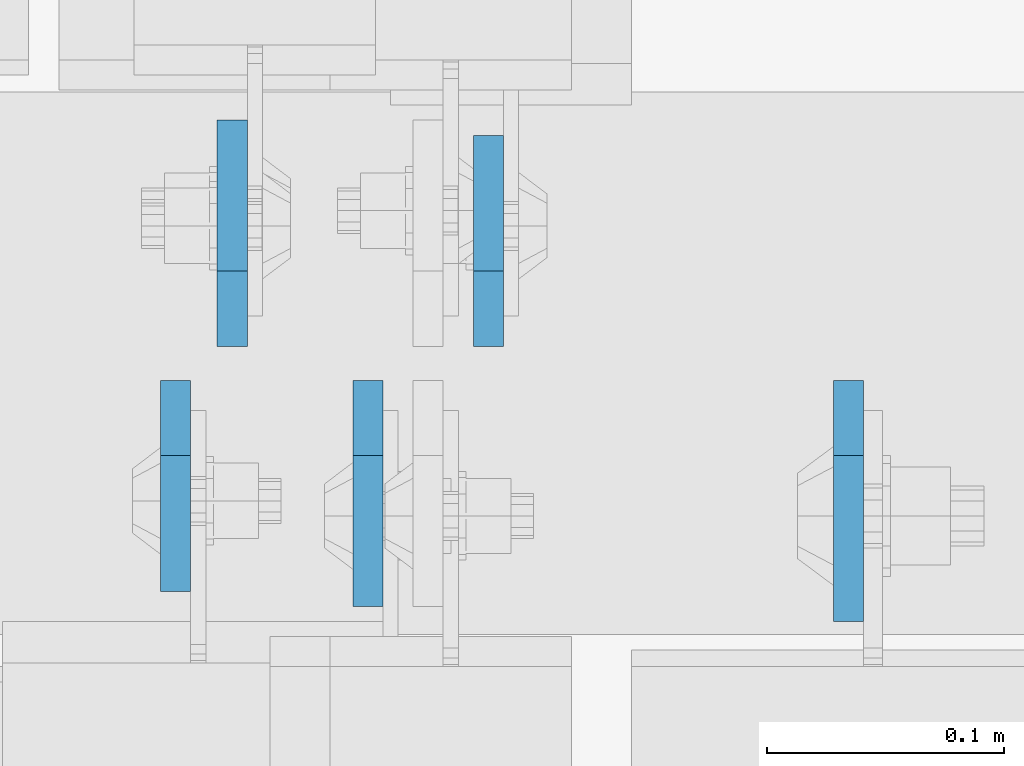
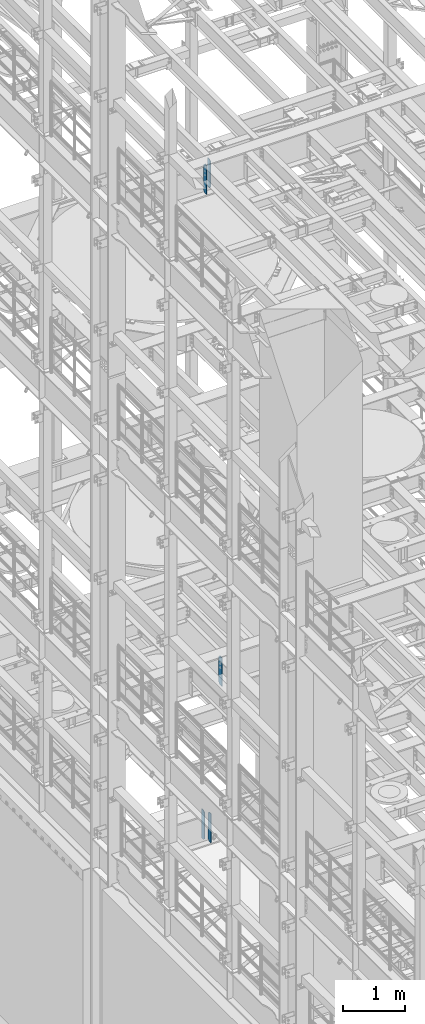
# One storey, part 1701 of 1876: 5 plates, 3 elements without a shape of their own.
"""IFC2X3 building model written with IfcOpenShell, lengths in millimetres."""

from ifc_helpers import new_model, si_unit, frame, origin_with_axes, place, context, subcontext, project, spatial, faceted_brep, material, type_object, element, aggregate, save


model = new_model("IFC2X3")

# Units and contexts
model_context = context("Model", 3, precision=1e-05, world=origin_with_axes())
body_context = subcontext(model_context, "Body", "Model", "MODEL_VIEW")
ifc_project = project(units=[si_unit("LENGTHUNIT", "METRE", prefix="MILLI"), si_unit("AREAUNIT", "SQUARE_METRE"), si_unit("VOLUMEUNIT", "CUBIC_METRE"), si_unit("MASSUNIT", "GRAM", prefix="KILO"), si_unit("TIMEUNIT", "SECOND"), si_unit("PLANEANGLEUNIT", "RADIAN"), si_unit("SOLIDANGLEUNIT", "STERADIAN"), si_unit("THERMODYNAMICTEMPERATUREUNIT", "DEGREE_CELSIUS"), si_unit("LUMINOUSINTENSITYUNIT", "LUMEN")], contexts=[model_context])

# Site, building, storey
site_placement = place(None, origin_with_axes())
site = spatial("IfcSite", under=ifc_project, at=site_placement, CompositionType="ELEMENT")
building_placement = place(site_placement, origin_with_axes())
building = spatial("IfcBuilding", under=site, at=building_placement, Name="Undefined", CompositionType="ELEMENT")
storey_placement = place(building_placement, origin_with_axes())
storey = spatial("IfcBuildingStorey", under=building, at=storey_placement, Name="Undefined", CompositionType="ELEMENT", Elevation=0.0)

# Assembly, plates
assembly_1_placement = place(storey_placement, origin_with_axes())
assembly_1 = element("IfcElementAssembly", 1, at=assembly_1_placement, inside=storey, Name="BEAM", AssemblyPlace="NOTDEFINED", PredefinedType="RIGID_FRAME")
ifc_material = material(Name="STEEL/A36")
plate_type_1 = type_object("IfcPlateType", PredefinedType="NOTDEFINED")
plate_1_placement = place(assembly_1_placement, frame((1789.11249990463, 7612.85625, 17386.3), z_axis=(0.0, 0.0, 1.0), x_axis=(0.0, -1.0, 0.0)))
plate_1 = element("IfcPlate", 2, at=plate_1_placement, type_object=plate_type_1, material=ifc_material, Name="PLATE", context=body_context, shape_type="Brep", body=[
    faceted_brep([(0.0, -6.34999999999991, 31.75), (0.0, -6.34999999999991, 539.75), (0.0, 6.34999999999991, 539.75), (0.0, 6.34999999999991, 31.75), (31.75, -6.34999999999991, 571.5), (31.75, 6.34999999999991, 571.5), (88.9000015258789, -6.34999999999991, 571.5), (88.9000015258789, 6.34999999999991, 571.5), (88.9000015258789, -6.34999999999991, 0.0), (88.9000015258789, 6.34999999999991, 0.0), (31.75, -6.34999999999991, 0.0), (31.75, 6.34999999999991, 0.0)], [[[0, 1, 2, 3]], [[1, 4, 5, 2]], [[4, 6, 7, 5]], [[6, 8, 9, 7]], [[8, 10, 11, 9]], [[10, 0, 3, 11]], [[5, 7, 9, 11, 3, 2]], [[10, 8, 6, 4, 1, 0]]]),
])
plate_2_placement = place(assembly_1_placement, frame((1920.87499990463, 7627.14375, 17386.3), z_axis=(0.0, 0.0, 1.0), x_axis=(0.0, 1.0, 0.0)))
plate_2 = element("IfcPlate", 3, at=plate_2_placement, type_object=plate_type_1, material=ifc_material, Name="PLATE", context=body_context, shape_type="Brep", body=[
    faceted_brep([(0.0, -6.34999999999991, 31.75), (0.0, -6.34999999999991, 539.75), (0.0, 6.34999999999991, 539.75), (0.0, 6.34999999999991, 31.75), (31.75, -6.34999999999991, 571.5), (31.75, 6.34999999999991, 571.5), (88.9000015258789, -6.34999999999991, 571.5), (88.9000015258789, 6.34999999999991, 571.5), (88.9000015258789, -6.34999999999991, 0.0), (88.9000015258789, 6.34999999999991, 0.0), (31.75, -6.34999999999991, 0.0), (31.75, 6.34999999999991, 0.0)], [[[0, 1, 2, 3]], [[1, 4, 5, 2]], [[4, 6, 7, 5]], [[6, 8, 9, 7]], [[8, 10, 11, 9]], [[10, 0, 3, 11]], [[5, 7, 9, 11, 3, 2]], [[10, 8, 6, 4, 1, 0]]]),
])
aggregate(assembly_1, [plate_1, plate_2])

assembly_2_placement = place(storey_placement, origin_with_axes())
assembly_2 = element("IfcElementAssembly", 4, at=assembly_2_placement, inside=storey, Name="BEAM", AssemblyPlace="NOTDEFINED", PredefinedType="RIGID_FRAME")
plate_type_2 = type_object("IfcPlateType", PredefinedType="NOTDEFINED")
plate_3_placement = place(assembly_2_placement, frame((1870.07499990463, 7612.85625, 4535.4875), z_axis=(0.0, 0.0, 1.0), x_axis=(0.0, -1.0, 0.0)))
plate_3 = element("IfcPlate", 5, at=plate_3_placement, type_object=plate_type_2, material=ifc_material, Name="PLATE", context=body_context, shape_type="Brep", body=[
    faceted_brep([(0.0, -6.34999999999991, 31.75), (0.0, -6.35000000000036, 538.162475585938), (0.0, 6.35000000000036, 538.162475585938), (0.0, 6.34999999999991, 31.75), (31.75, -6.35000000000036, 569.912475585938), (31.75, 6.35000000000036, 569.912475585938), (95.25, -6.35000000000036, 569.912475585938), (95.25, 6.35000000000036, 569.912475585938), (95.25, -6.35000000000036, 0.0), (95.25, 6.35000000000036, 0.0), (31.75, -6.34999999999991, 0.0), (31.75, 6.34999999999991, 0.0)], [[[0, 1, 2, 3]], [[1, 4, 5, 2]], [[4, 6, 7, 5]], [[6, 8, 9, 7]], [[8, 10, 11, 9]], [[10, 0, 3, 11]], [[5, 7, 9, 11, 3, 2]], [[10, 8, 6, 4, 1, 0]]]),
])
plate_4_placement = place(assembly_2_placement, frame((1812.92499990463, 7627.14375, 4535.4875), z_axis=(0.0, 0.0, 1.0), x_axis=(0.0, 1.0, 0.0)))
plate_4 = element("IfcPlate", 6, at=plate_4_placement, type_object=plate_type_2, material=ifc_material, Name="PLATE", context=body_context, shape_type="Brep", body=[
    faceted_brep([(0.0, -6.34999999999991, 31.75), (0.0, -6.35000000000036, 538.162475585938), (0.0, 6.35000000000036, 538.162475585938), (0.0, 6.34999999999991, 31.75), (31.75, -6.35000000000036, 569.912475585938), (31.75, 6.35000000000036, 569.912475585938), (95.25, -6.35000000000036, 569.912475585938), (95.25, 6.35000000000036, 569.912475585938), (95.25, -6.35000000000036, 0.0), (95.25, 6.35000000000036, 0.0), (31.75, -6.34999999999991, 0.0), (31.75, 6.34999999999991, 0.0)], [[[0, 1, 2, 3]], [[1, 4, 5, 2]], [[4, 6, 7, 5]], [[6, 8, 9, 7]], [[8, 10, 11, 9]], [[10, 0, 3, 11]], [[5, 7, 9, 11, 3, 2]], [[10, 8, 6, 4, 1, 0]]]),
])
aggregate(assembly_2, [plate_3, plate_4])

# Assembly, plate
assembly_3_placement = place(storey_placement, origin_with_axes())
assembly_3 = element("IfcElementAssembly", 7, at=assembly_3_placement, inside=storey, Name="BEAM", AssemblyPlace="NOTDEFINED", PredefinedType="RIGID_FRAME")
plate_type_3 = type_object("IfcPlateType", PredefinedType="NOTDEFINED")
plate_5_placement = place(assembly_3_placement, frame((2072.48124990463, 7612.85625, 7558.0875), z_axis=(0.0, 0.0, 1.0), x_axis=(0.0, -1.0, 0.0)))
plate_5 = element("IfcPlate", 8, at=plate_5_placement, type_object=plate_type_3, material=ifc_material, Name="PLATE", context=body_context, shape_type="Brep", body=[
    faceted_brep([(0.0, -6.34999999999991, 31.75), (0.0, -6.35000000000036, 538.162475585938), (0.0, 6.35000000000036, 538.162475585938), (0.0, 6.34999999999991, 31.75), (31.75, -6.35000000000036, 569.912475585938), (31.75, 6.35000000000036, 569.912475585938), (101.599998474121, -6.34999999999991, 569.912475585938), (101.599998474121, 6.34999999999991, 569.912475585938), (101.599998474121, -6.35000000000036, 0.0), (101.599998474121, 6.35000000000036, 0.0), (31.75, -6.34999999999991, 0.0), (31.75, 6.34999999999991, 0.0)], [[[0, 1, 2, 3]], [[1, 4, 5, 2]], [[4, 6, 7, 5]], [[6, 8, 9, 7]], [[8, 10, 11, 9]], [[10, 0, 3, 11]], [[5, 7, 9, 11, 3, 2]], [[10, 8, 6, 4, 1, 0]]]),
])
aggregate(assembly_3, [plate_5])

save(model, "model.ifc")
